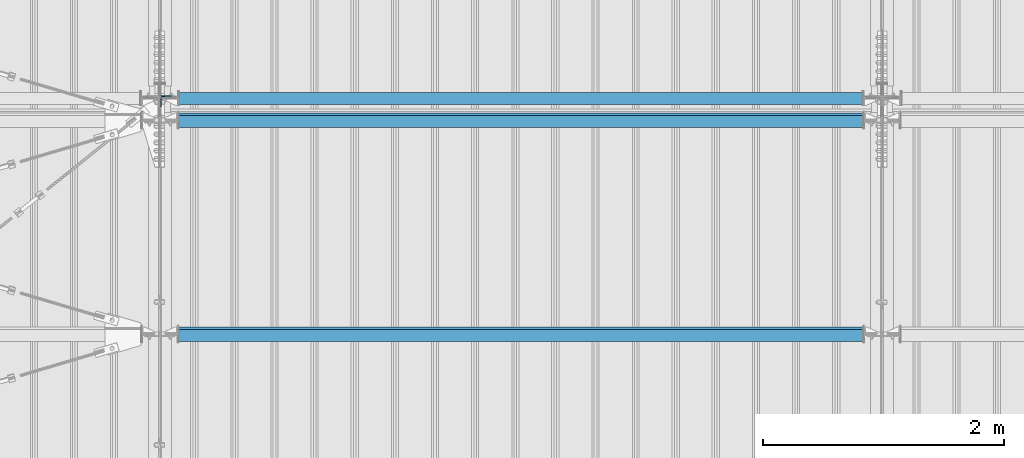
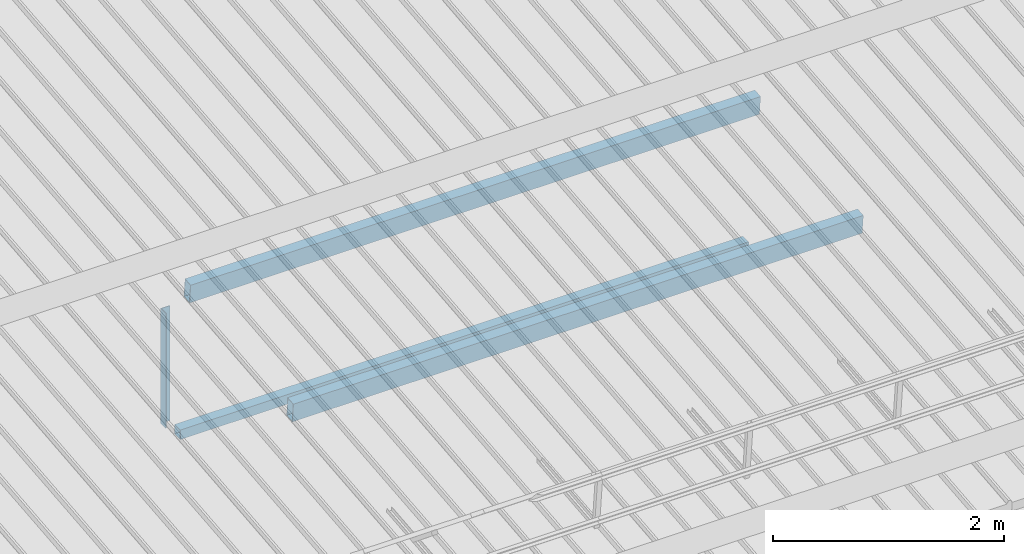
# One storey, part 244 of 709: 4 beams, 4 elements without a shape of their own.
"""IFC4 building model written with IfcOpenShell, lengths in millimetres."""

from ifc_helpers import new_model, si_unit, direction, frame, origin_with_axes, place, context, subcontext, project, spatial, polygons, material, element, aggregate, save


model = new_model("IFC4")

# Units and contexts
model_context = context("Model", 3, precision=0.2, world=origin_with_axes(), true_north=direction((0.0, 1.0)))
body_context = subcontext(model_context, "Body", "Model", "MODEL_VIEW")
ifc_project = project(units=[si_unit("LENGTHUNIT", "METRE", prefix="MILLI"), si_unit("AREAUNIT", "SQUARE_METRE"), si_unit("VOLUMEUNIT", "CUBIC_METRE"), si_unit("MASSUNIT", "GRAM", prefix="KILO"), si_unit("TIMEUNIT", "SECOND"), si_unit("PLANEANGLEUNIT", "RADIAN"), si_unit("SOLIDANGLEUNIT", "STERADIAN"), si_unit("THERMODYNAMICTEMPERATUREUNIT", "DEGREE_CELSIUS"), si_unit("LUMINOUSINTENSITYUNIT", "LUMEN")], contexts=[model_context])

# Site, building, storey
site_placement = place(None, origin_with_axes())
site = spatial("IfcSite", under=ifc_project, at=site_placement, CompositionType="ELEMENT")
building_placement = place(site_placement, origin_with_axes())
building = spatial("IfcBuilding", under=site, at=building_placement, Name="Undefined", CompositionType="ELEMENT")
storey_placement = place(building_placement, origin_with_axes())
storey = spatial("IfcBuildingStorey", under=building, at=storey_placement, Name="Undefined", CompositionType="ELEMENT", Elevation=0.0)

# Assembly, beam
assembly_1_placement = place(storey_placement, frame((10051.0, 5648.7, 7622.40002), z_axis=(0.0, -1.0, 0.0), x_axis=(0.0, 0.0, -1.0)))
assembly_1 = element("IfcElementAssembly", 1, at=assembly_1_placement, inside=storey)
ifc_material_1 = material(Name="C345-5", Category="STEEL")
beam_1_placement = place(assembly_1_placement, origin_with_axes())
beam_1 = element("IfcBeam", 2, at=beam_1_placement, material=ifc_material_1, ObjectType="436", context=body_context, shape_type="Tessellation", body=[
    polygons([(199.0491, -45.0, -45.0), (199.0491, 45.0, -45.0), (1412.4, 45.0, -45.0), (1412.4, -45.0, -45.0), (199.0491, 45.0, -39.0), (1412.4, 45.0, -39.0), (199.0491, -39.0, -39.0), (1412.4, -39.0, -39.0), (199.0491, -39.0, 45.0), (1412.4, -39.0, 45.0), (199.0491, -45.0, 45.0), (1412.4, -45.0, 45.0)], [[[1, 2, 3, 4]], [[2, 5, 6, 3]], [[5, 7, 8, 6]], [[7, 9, 10, 8]], [[9, 11, 12, 10]], [[11, 1, 4, 12]], [[6, 8, 10, 12, 4, 3]], [[11, 9, 7, 5, 2, 1]]], closed=True),
])
aggregate(assembly_1, [beam_1])

assembly_2_placement = place(storey_placement, frame((10000.0, 5673.0, 6074.30002), z_axis=(0.0, -1.0, 0.0), x_axis=(1.0, 0.0, 0.0)))
assembly_2 = element("IfcElementAssembly", 3, at=assembly_2_placement, inside=storey)
ifc_material_2 = material(Name="C355", Category="STEEL")
beam_2_placement = place(assembly_2_placement, origin_with_axes())
beam_2 = element("IfcBeam", 4, at=beam_2_placement, material=ifc_material_2, ObjectType="557", context=body_context, shape_type="Tessellation", body=[
    polygons([(162.0, -47.0, -47.0), (162.0, -47.0, 47.0), (5838.0, -47.0, 47.0), (5838.0, -47.0, -47.0), (162.0, 47.0, 47.0), (5838.0, 47.0, 47.0), (162.0, 47.0, -47.0), (5838.0, 47.0, -47.0), (162.0, -50.0, -50.0), (162.0, 50.0, -50.0), (5838.0, 50.0, -50.0), (5838.0, -50.0, -50.0), (162.0, 50.0, 50.0), (5838.0, 50.0, 50.0), (162.0, -50.0, 50.0), (5838.0, -50.0, 50.0)], [[[1, 2, 3, 4]], [[2, 5, 6, 3]], [[5, 7, 8, 6]], [[7, 1, 4, 8]], [[9, 10, 11, 12]], [[10, 13, 14, 11]], [[13, 15, 16, 14]], [[15, 9, 12, 16]], [[14, 16, 12, 11], [6, 8, 4, 3]], [[15, 13, 10, 9], [7, 5, 2, 1]]], closed=True),
])
aggregate(assembly_2, [beam_2])

assembly_3_placement = place(storey_placement, frame((10000.0, 3713.34988, 7499.7991), z_axis=(0.0, 0.9950371902, 0.099503719), x_axis=(1.0, 0.0, 0.0)))
assembly_3 = element("IfcElementAssembly", 5, at=assembly_3_placement, inside=storey)
beam_3_placement = place(assembly_3_placement, origin_with_axes())
beam_3 = element("IfcBeam", 6, at=beam_3_placement, material=ifc_material_2, ObjectType="579", context=body_context, shape_type="Tessellation", body=[
    polygons([(155.0, -96.0, -46.0), (155.0, -96.0, 46.0), (5845.0, -96.0, 46.0), (5845.0, -96.0, -46.0), (155.0, 96.0, 46.0), (5845.0, 96.0, 46.0), (155.0, 96.0, -46.0), (5845.0, 96.0, -46.0), (155.0, -100.0, -50.0), (155.0, 100.0, -50.0), (5845.0, 100.0, -50.0), (5845.0, -100.0, -50.0), (155.0, 100.0, 50.0), (5845.0, 100.0, 50.0), (155.0, -100.0, 50.0), (5845.0, -100.0, 50.0)], [[[1, 2, 3, 4]], [[2, 5, 6, 3]], [[5, 7, 8, 6]], [[7, 1, 4, 8]], [[9, 10, 11, 12]], [[10, 13, 14, 11]], [[13, 15, 16, 14]], [[15, 9, 12, 16]], [[14, 16, 12, 11], [6, 8, 4, 3]], [[15, 13, 10, 9], [7, 5, 2, 1]]], closed=True),
])
aggregate(assembly_3, [beam_3])

assembly_4_placement = place(storey_placement, frame((10000.0, 5490.04963, 7677.46908), z_axis=(0.0, 0.9950371902, 0.099503719), x_axis=(1.0, 0.0, 0.0)))
assembly_4 = element("IfcElementAssembly", 7, at=assembly_4_placement, inside=storey)
beam_4_placement = place(assembly_4_placement, origin_with_axes())
beam_4 = element("IfcBeam", 8, at=beam_4_placement, material=ifc_material_2, ObjectType="579", context=body_context, shape_type="Tessellation", body=[
    polygons([(155.0, -96.0, -46.0), (155.0, -96.0, 46.0), (5845.0, -96.0, 46.0), (5845.0, -96.0, -46.0), (155.0, 96.0, 46.0), (5845.0, 96.0, 46.0), (155.0, 96.0, -46.0), (5845.0, 96.0, -46.0), (155.0, -100.0, -50.0), (155.0, 100.0, -50.0), (5845.0, 100.0, -50.0), (5845.0, -100.0, -50.0), (155.0, 100.0, 50.0), (5845.0, 100.0, 50.0), (155.0, -100.0, 50.0), (5845.0, -100.0, 50.0)], [[[1, 2, 3, 4]], [[2, 5, 6, 3]], [[5, 7, 8, 6]], [[7, 1, 4, 8]], [[9, 10, 11, 12]], [[10, 13, 14, 11]], [[13, 15, 16, 14]], [[15, 9, 12, 16]], [[14, 16, 12, 11], [6, 8, 4, 3]], [[15, 13, 10, 9], [7, 5, 2, 1]]], closed=True),
])
aggregate(assembly_4, [beam_4])

save(model, "model.ifc")
